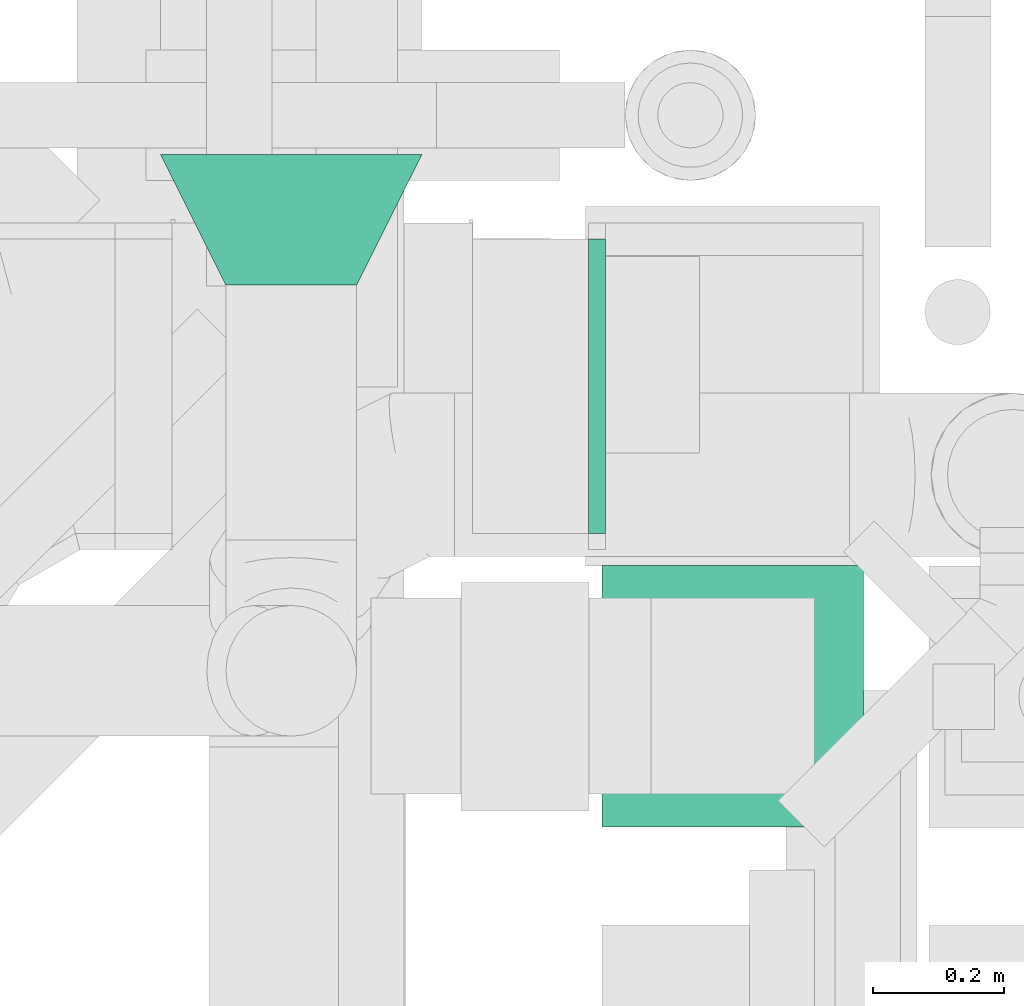
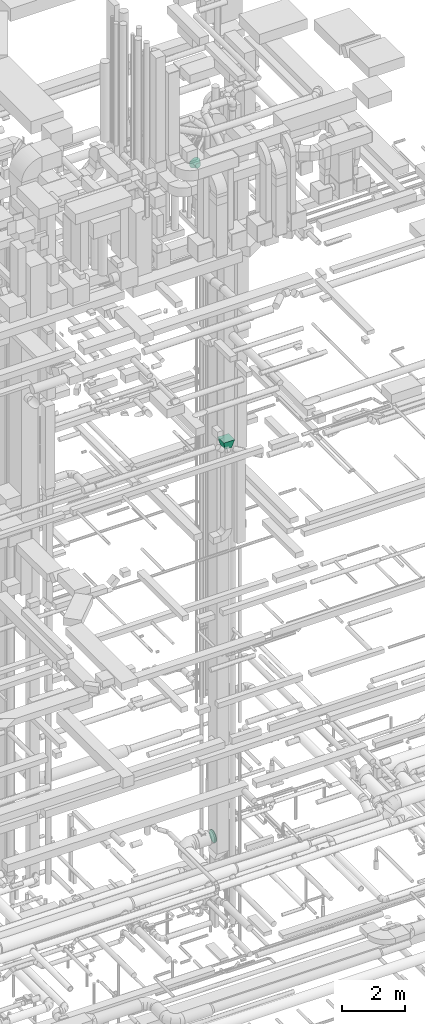
# One storey, part 329 of 337: 3 flow fittings.
"""IFC2X3 building model written with IfcOpenShell, lengths in millimetres."""

from ifc_helpers import new_model, entity, si_unit, converted_unit, derived_unit, direction, frame, origin, place, context, subcontext, project, spatial, faceted_brep, source, transform, mapped, material, type_object, type_shapes, element, save


model = new_model("IFC2X3")

# Units and contexts
model_context = context("Model", 3, precision=0.01, world=origin(), true_north=direction((6.12303176911189e-17, 1.0)))
body_context = subcontext(model_context, "Body", "Model", "MODEL_VIEW")
ifc_project = project(units=[si_unit("LENGTHUNIT", "METRE", prefix="MILLI"), si_unit("AREAUNIT", "SQUARE_METRE"), si_unit("VOLUMEUNIT", "CUBIC_METRE"), converted_unit("PLANEANGLEUNIT", "DEGREE", entity("IfcRatioMeasure", 0.0174532925199433), si_unit("PLANEANGLEUNIT", "RADIAN"), dimensions=[0, 0, 0, 0, 0, 0, 0]), si_unit("MASSUNIT", "GRAM", prefix="KILO"), derived_unit("MASSDENSITYUNIT", [(si_unit("MASSUNIT", "GRAM", prefix="KILO"), 1), (si_unit("LENGTHUNIT", "METRE"), -3)]), derived_unit("MOMENTOFINERTIAUNIT", [(si_unit("LENGTHUNIT", "METRE"), 4)]), si_unit("TIMEUNIT", "SECOND"), si_unit("FREQUENCYUNIT", "HERTZ"), si_unit("THERMODYNAMICTEMPERATUREUNIT", "DEGREE_CELSIUS"), derived_unit("THERMALTRANSMITTANCEUNIT", [(si_unit("MASSUNIT", "GRAM", prefix="KILO"), 1), (si_unit("THERMODYNAMICTEMPERATUREUNIT", "KELVIN"), -1), (si_unit("TIMEUNIT", "SECOND"), -3)]), derived_unit("VOLUMETRICFLOWRATEUNIT", [(si_unit("LENGTHUNIT", "METRE"), 3), (si_unit("TIMEUNIT", "SECOND"), -1)]), derived_unit("MASSFLOWRATEUNIT", [(si_unit("MASSUNIT", "GRAM", prefix="KILO"), 1), (si_unit("TIMEUNIT", "SECOND"), -1)]), derived_unit("ROTATIONALFREQUENCYUNIT", [(si_unit("TIMEUNIT", "SECOND"), -1)]), si_unit("ELECTRICCURRENTUNIT", "AMPERE"), si_unit("ELECTRICVOLTAGEUNIT", "VOLT"), si_unit("POWERUNIT", "WATT"), si_unit("FORCEUNIT", "NEWTON", prefix="KILO"), si_unit("ILLUMINANCEUNIT", "LUX"), si_unit("LUMINOUSFLUXUNIT", "LUMEN"), si_unit("LUMINOUSINTENSITYUNIT", "CANDELA"), derived_unit("USERDEFINED", [(si_unit("MASSUNIT", "GRAM", prefix="KILO"), -1), (si_unit("LENGTHUNIT", "METRE"), -2), (si_unit("TIMEUNIT", "SECOND"), 3), (si_unit("LUMINOUSFLUXUNIT", "LUMEN"), 1)]), derived_unit("LINEARVELOCITYUNIT", [(si_unit("LENGTHUNIT", "METRE"), 1), (si_unit("TIMEUNIT", "SECOND"), -1)]), si_unit("PRESSUREUNIT", "PASCAL"), derived_unit("USERDEFINED", [(si_unit("LENGTHUNIT", "METRE"), -2), (si_unit("MASSUNIT", "GRAM", prefix="KILO"), 1), (si_unit("TIMEUNIT", "SECOND"), -2)]), derived_unit("LINEARFORCEUNIT", [(si_unit("MASSUNIT", "GRAM", prefix="KILO"), 1), (si_unit("LENGTHUNIT", "METRE"), 1), (si_unit("TIMEUNIT", "SECOND"), -2), (si_unit("LENGTHUNIT", "METRE"), -1)]), derived_unit("PLANARFORCEUNIT", [(si_unit("MASSUNIT", "GRAM", prefix="KILO"), 1), (si_unit("LENGTHUNIT", "METRE"), 1), (si_unit("TIMEUNIT", "SECOND"), -2), (si_unit("LENGTHUNIT", "METRE"), -2)])], contexts=[model_context])

# Site, building, storey
site_placement = place(None, origin())
site = spatial("IfcSite", under=ifc_project, at=site_placement, CompositionType="ELEMENT")
building_placement = place(site_placement, origin())
building = spatial("IfcBuilding", under=site, at=building_placement, CompositionType="ELEMENT")
storey_placement = place(building_placement, origin())
storey = spatial("IfcBuildingStorey", under=building, at=storey_placement, CompositionType="ELEMENT", Elevation=0.0)

# Flow fittings
ifc_material = material()
duct_fitting_type_1 = type_object("IfcDuctFittingType", PredefinedType="NOTDEFINED", material=ifc_material)
shared_shape_1 = source(origin(), body_context, "Body", "Brep", [
    faceted_brep([(200.0, 80.9, -58.78), (200.0, 95.11, -30.9), (200.0, 100.0, 0.0), (200.0, 95.11, 30.9), (200.0, 80.9, 58.78), (200.0, 58.78, 80.9), (200.0, 30.9, 95.11), (200.0, 0.0, 100.0), (200.0, -30.9, 95.11), (200.0, -58.78, 80.9), (200.0, -80.9, 58.78), (200.0, -95.11, 30.9), (200.0, -100.0, 0.0), (200.0, -95.11, -30.9), (200.0, -80.9, -58.78), (200.0, -58.78, -80.9), (200.0, -30.9, -95.11), (200.0, 0.0, -100.0), (200.0, 30.9, -95.11), (200.0, 58.78, -80.9), (0.0, -44.5, -194.99), (0.0, -86.78, -180.19), (0.0, -124.7, -156.37), (0.0, -156.37, -124.7), (0.0, -180.19, -86.78), (0.0, -194.99, -44.5), (0.0, -200.0, 0.0), (0.0, -194.99, 44.5), (0.0, -180.19, 86.78), (0.0, -156.37, 124.7), (0.0, -124.7, 156.37), (0.0, -86.78, 180.19), (0.0, -44.5, 194.99), (0.0, 0.0, 200.0), (0.0, 44.5, 194.99), (0.0, 86.78, 180.19), (0.0, 124.7, 156.37), (0.0, 156.37, 124.7), (0.0, 180.19, 86.78), (0.0, 194.99, 44.5), (0.0, 200.0, 0.0), (0.0, 194.99, -44.5), (0.0, 180.19, -86.78), (0.0, 156.37, -124.7), (0.0, 124.7, -156.37), (0.0, 86.78, -180.19), (0.0, 44.5, -194.99), (0.0, 0.0, -200.0)], [[[0, 1, 2, 3, 4, 5, 6, 7, 8, 9, 10, 11, 12, 13, 14, 15, 16, 17, 18, 19]], [[20, 21, 22, 23, 24, 25, 26, 27, 28, 29, 30, 31, 32, 33, 34, 35, 36, 37, 38, 39, 40, 41, 42, 43, 44, 45, 46, 47]], [[34, 7, 6]], [[35, 6, 5]], [[33, 7, 34]], [[35, 34, 6]], [[36, 35, 5]], [[5, 4, 37, 36]], [[3, 2, 39]], [[4, 3, 38]], [[38, 37, 4]], [[40, 39, 2]], [[38, 3, 39]], [[27, 12, 11]], [[28, 11, 10]], [[26, 12, 27]], [[28, 27, 11]], [[29, 28, 10]], [[10, 9, 30, 29]], [[8, 7, 32]], [[9, 8, 31]], [[31, 30, 9]], [[33, 32, 7]], [[31, 8, 32]], [[20, 17, 16]], [[21, 16, 15]], [[47, 17, 20]], [[21, 20, 16]], [[22, 21, 15]], [[15, 14, 23, 22]], [[13, 12, 25]], [[14, 13, 24]], [[24, 23, 14]], [[26, 25, 12]], [[24, 13, 25]], [[41, 2, 1]], [[42, 1, 0]], [[40, 2, 41]], [[42, 41, 1]], [[43, 42, 0]], [[0, 19, 44, 43]], [[18, 17, 46]], [[19, 18, 45]], [[45, 44, 19]], [[47, 46, 17]], [[45, 18, 46]]]),
])
type_shapes(duct_fitting_type_1, [shared_shape_1])
flow_fitting_1_placement = place(storey_placement, frame((58305.03, 11794.26, 29300.0), z_axis=(0.0, -1.38325265102102e-08, 1.0), x_axis=(0.0, -1.0, -1.38325265102102e-08)))
element("IfcFlowFitting", 1, at=flow_fitting_1_placement, inside=storey, type_object=duct_fitting_type_1, material=ifc_material, context=body_context, shape_type="MappedRepresentation", body=[
    mapped(shared_shape_1, transform((0.0, 0.0, 0.0), scale=1.0)),
])
duct_fitting_type_2 = type_object("IfcDuctFittingType", PredefinedType="NOTDEFINED", material=ifc_material)
shared_shape_2 = source(origin(), body_context, "Body", "Brep", [
    faceted_brep([(20.01, 225.0, 0.0), (20.01, 219.36, 50.07), (20.01, 202.72, 97.62), (20.01, 175.91, 140.29), (20.01, 140.29, 175.91), (20.01, 97.62, 202.72), (20.01, 50.07, 219.36), (20.01, 0.0, 225.0), (20.01, -50.07, 219.36), (20.01, -97.62, 202.72), (20.01, -140.29, 175.91), (20.01, -175.91, 140.29), (20.01, -202.72, 97.62), (20.01, -219.36, 50.07), (20.01, -225.0, 0.0), (20.01, -219.36, -50.07), (20.01, -202.72, -97.62), (20.01, -175.91, -140.29), (20.01, -140.29, -175.91), (20.01, -97.62, -202.72), (20.01, -50.07, -219.36), (20.01, 0.0, -225.0), (20.01, 50.07, -219.36), (20.01, 97.62, -202.72), (20.01, 140.29, -175.91), (20.01, 175.91, -140.29), (20.01, 202.72, -97.62), (20.01, 219.36, -50.07), (0.0, 0.0, 225.0), (0.0, 32.46, 221.34), (-6.1, 25.03, 222.18), (-6.1, 0.0, 225.0), (0.0, 50.07, 219.36), (-6.1, 50.07, 219.36), (0.0, 73.85, 211.04), (0.0, 97.62, 202.72), (-6.1, 73.85, 211.04), (-6.1, 97.62, 202.72), (0.0, 118.95, 189.32), (0.0, 140.29, 175.91), (-6.1, 118.95, 189.32), (-6.1, 140.29, 175.91), (0.0, 158.1, 158.1), (0.0, 175.91, 140.29), (-6.1, 158.1, 158.1), (-6.1, 175.91, 140.29), (0.0, 189.32, 118.95), (0.0, 202.72, 97.62), (-6.1, 189.32, 118.95), (-6.1, 202.72, 97.62), (0.0, 211.04, 73.85), (0.0, 219.36, 50.07), (-6.1, 211.04, 73.85), (-6.1, 219.36, 50.07), (0.0, 222.18, 25.03), (-6.1, 221.34, 32.46), (0.0, 225.0, 0.0), (-6.1, 225.0, 0.0), (0.0, 221.34, -32.46), (-6.1, 222.18, -25.03), (0.0, 219.36, -50.07), (-6.1, 219.36, -50.07), (0.0, 211.04, -73.85), (0.0, 202.72, -97.62), (-6.1, 211.04, -73.85), (-6.1, 202.72, -97.62), (0.0, 189.32, -118.95), (0.0, 175.91, -140.29), (-6.1, 189.32, -118.95), (-6.1, 175.91, -140.29), (0.0, 140.29, -175.91), (0.0, 158.1, -158.1), (-6.1, 158.1, -158.1), (-6.1, 140.29, -175.91), (0.0, 118.95, -189.32), (0.0, 97.62, -202.72), (-6.1, 118.95, -189.32), (-6.1, 97.62, -202.72), (0.0, 50.07, -219.36), (0.0, 73.85, -211.04), (-6.1, 50.07, -219.36), (-6.1, 73.85, -211.04), (0.0, 0.0, -225.0), (0.0, 32.46, -221.34), (-6.1, 25.03, -222.18), (-6.1, 0.0, -225.0), (0.0, -32.46, -221.34), (-6.1, -25.03, -222.18), (0.0, -50.07, -219.36), (-6.1, -50.07, -219.36), (0.0, -73.85, -211.04), (0.0, -97.62, -202.72), (-6.1, -73.85, -211.04), (-6.1, -97.62, -202.72), (0.0, -118.95, -189.32), (0.0, -140.29, -175.91), (-6.1, -118.95, -189.32), (-6.1, -140.29, -175.91), (0.0, -158.1, -158.1), (0.0, -175.91, -140.29), (-6.1, -158.1, -158.1), (-6.1, -175.91, -140.29), (0.0, -189.32, -118.95), (0.0, -202.72, -97.62), (-6.1, -189.32, -118.95), (-6.1, -202.72, -97.62), (0.0, -225.0, 0.0), (0.0, -221.34, -32.46), (0.0, -219.36, -50.07), (-6.1, -222.18, -25.03), (-6.1, -225.0, 0.0), (-6.1, -219.36, -50.07), (0.0, -211.04, -73.85), (-6.1, -211.04, -73.85), (0.0, -221.34, 32.46), (-6.1, -222.18, 25.03), (0.0, -219.36, 50.07), (-6.1, -219.36, 50.07), (0.0, -211.04, 73.85), (0.0, -202.72, 97.62), (-6.1, -211.04, 73.85), (-6.1, -202.72, 97.62), (0.0, -189.32, 118.95), (0.0, -175.91, 140.29), (-6.1, -189.32, 118.95), (-6.1, -175.91, 140.29), (0.0, -158.1, 158.1), (0.0, -140.29, 175.91), (-6.1, -158.1, 158.1), (-6.1, -140.29, 175.91), (0.0, -118.95, 189.32), (0.0, -97.62, 202.72), (-6.1, -118.95, 189.32), (-6.1, -97.62, 202.72), (0.0, -50.07, 219.36), (0.0, -25.03, 222.18), (-6.1, -32.46, 221.34), (-6.1, -50.07, 219.36), (0.0, -73.85, 211.04), (-6.1, -73.85, 211.04)], [[[0, 1, 2, 3, 4, 5, 6, 7, 8, 9, 10, 11, 12, 13, 14, 15, 16, 17, 18, 19, 20, 21, 22, 23, 24, 25, 26, 27]], [[28, 7, 6]], [[6, 29, 28]], [[28, 29, 30]], [[31, 28, 30]], [[6, 32, 29]], [[32, 33, 29]], [[29, 33, 30]], [[6, 5, 32]], [[5, 34, 32]], [[5, 35, 34]], [[36, 34, 35]], [[35, 37, 36]], [[33, 34, 36]], [[34, 33, 32]], [[4, 35, 5]], [[4, 38, 35]], [[4, 39, 38]], [[38, 39, 40]], [[39, 41, 40]], [[37, 38, 40]], [[38, 37, 35]], [[4, 3, 39]], [[3, 42, 39]], [[3, 43, 42]], [[44, 42, 43]], [[43, 45, 44]], [[41, 42, 44]], [[39, 42, 41]], [[43, 3, 2]], [[2, 46, 43]], [[45, 43, 46]], [[2, 47, 46]], [[47, 48, 46]], [[47, 49, 48]], [[45, 46, 48]], [[47, 2, 1]], [[1, 50, 47]], [[50, 49, 47]], [[1, 51, 50]], [[52, 50, 51]], [[51, 53, 52]], [[49, 50, 52]], [[51, 1, 0]], [[0, 54, 51]], [[55, 51, 54]], [[51, 55, 53]], [[0, 56, 54]], [[56, 57, 54]], [[57, 55, 54]], [[56, 0, 27]], [[27, 58, 56]], [[56, 58, 59]], [[57, 56, 59]], [[27, 60, 58]], [[60, 61, 58]], [[58, 61, 59]], [[27, 26, 60]], [[26, 62, 60]], [[26, 63, 62]], [[64, 62, 63]], [[63, 65, 64]], [[61, 62, 64]], [[62, 61, 60]], [[25, 63, 26]], [[25, 66, 63]], [[25, 67, 66]], [[66, 67, 68]], [[67, 69, 68]], [[65, 66, 68]], [[66, 65, 63]], [[25, 70, 71]], [[24, 70, 25]], [[25, 71, 67]], [[72, 71, 70]], [[70, 73, 72]], [[69, 71, 72]], [[67, 71, 69]], [[24, 23, 70]], [[23, 74, 70]], [[23, 75, 74]], [[75, 76, 74]], [[75, 77, 76]], [[73, 74, 76]], [[73, 70, 74]], [[23, 22, 78]], [[23, 78, 79]], [[23, 79, 75]], [[79, 78, 80]], [[79, 80, 81]], [[81, 75, 79]], [[75, 81, 77]], [[82, 22, 21]], [[22, 82, 83]], [[82, 84, 83]], [[82, 85, 84]], [[80, 83, 84]], [[83, 80, 78]], [[22, 83, 78]], [[82, 21, 20]], [[20, 86, 82]], [[82, 86, 87]], [[85, 82, 87]], [[20, 88, 86]], [[88, 89, 86]], [[86, 89, 87]], [[20, 19, 88]], [[19, 90, 88]], [[19, 91, 90]], [[92, 90, 91]], [[91, 93, 92]], [[89, 90, 92]], [[90, 89, 88]], [[18, 91, 19]], [[18, 94, 91]], [[18, 95, 94]], [[94, 95, 96]], [[95, 97, 96]], [[93, 94, 96]], [[94, 93, 91]], [[18, 17, 95]], [[17, 98, 95]], [[17, 99, 98]], [[100, 98, 99]], [[99, 101, 100]], [[97, 98, 100]], [[95, 98, 97]], [[17, 16, 99]], [[16, 102, 99]], [[16, 103, 102]], [[104, 102, 103]], [[103, 105, 104]], [[101, 102, 104]], [[102, 101, 99]], [[15, 14, 106]], [[15, 106, 107]], [[15, 107, 108]], [[106, 109, 107]], [[106, 110, 109]], [[111, 107, 109]], [[107, 111, 108]], [[16, 15, 103]], [[15, 112, 103]], [[15, 108, 112]], [[112, 108, 111]], [[111, 113, 112]], [[105, 112, 113]], [[112, 105, 103]], [[106, 14, 13]], [[13, 114, 106]], [[106, 114, 115]], [[110, 106, 115]], [[13, 116, 114]], [[116, 117, 114]], [[114, 117, 115]], [[13, 12, 116]], [[12, 118, 116]], [[12, 119, 118]], [[120, 118, 119]], [[119, 121, 120]], [[117, 118, 120]], [[118, 117, 116]], [[11, 119, 12]], [[11, 122, 119]], [[11, 123, 122]], [[122, 123, 124]], [[123, 125, 124]], [[121, 122, 124]], [[122, 121, 119]], [[11, 10, 123]], [[10, 126, 123]], [[10, 127, 126]], [[128, 126, 127]], [[127, 129, 128]], [[125, 126, 128]], [[123, 126, 125]], [[127, 10, 9]], [[9, 130, 127]], [[129, 127, 130]], [[9, 131, 130]], [[131, 132, 130]], [[131, 133, 132]], [[129, 130, 132]], [[8, 7, 134]], [[7, 135, 134]], [[7, 28, 135]], [[135, 28, 31]], [[31, 136, 135]], [[136, 134, 135]], [[134, 136, 137]], [[131, 9, 8]], [[8, 138, 131]], [[131, 138, 133]], [[8, 134, 138]], [[134, 139, 138]], [[134, 137, 139]], [[133, 138, 139]], [[87, 89, 92, 93, 96, 97, 100, 101, 104, 105, 113, 111, 109, 110, 115, 117, 120, 121, 124, 125, 128, 129, 132, 133, 139, 137, 136, 31, 30, 33, 36, 37, 40, 41, 44, 45, 48, 49, 52, 53, 55, 57, 59, 61, 64, 65, 68, 69, 72, 73, 76, 77, 81, 80, 84, 85]]]),
])
type_shapes(duct_fitting_type_2, [shared_shape_2])
flow_fitting_2_placement = place(storey_placement, frame((58779.91, 11439.57, 3165.82), z_axis=(0.0, 1.0, 0.0), x_axis=(-1.0, 0.0, 0.0)))
element("IfcFlowFitting", 2, at=flow_fitting_2_placement, inside=storey, type_object=duct_fitting_type_2, material=ifc_material, context=body_context, shape_type="MappedRepresentation", body=[
    mapped(shared_shape_2, transform((0.0, 0.0, 0.0), scale=1.0)),
])
duct_fitting_type_3 = type_object("IfcDuctFittingType", PredefinedType="NOTDEFINED", material=ifc_material)
shared_shape_3 = source(origin(), body_context, "Body", "Brep", [
    faceted_brep([(300.0, -200.0, 200.0), (300.0, -200.0, -200.0), (300.0, 200.0, -200.0), (300.0, 200.0, 200.0), (0.0, -150.0, 125.0), (0.0, 150.0, 125.0), (0.0, 150.0, -125.0), (0.0, -150.0, -125.0)], [[[0, 1, 2, 3]], [[4, 5, 6, 7]], [[4, 7, 1, 0]], [[7, 6, 2, 1]], [[6, 5, 3, 2]], [[5, 4, 0, 3]]]),
])
type_shapes(duct_fitting_type_3, [shared_shape_3])
flow_fitting_3_placement = place(storey_placement, frame((58980.38, 10965.63, 18544.46), z_axis=(1.0, 0.0, 0.0), x_axis=(0.0, 0.0, 1.0)))
element("IfcFlowFitting", 3, at=flow_fitting_3_placement, inside=storey, type_object=duct_fitting_type_3, material=ifc_material, context=body_context, shape_type="MappedRepresentation", body=[
    mapped(shared_shape_3, transform((0.0, 0.0, 0.0), scale=1.0)),
])

save(model, "model.ifc")
